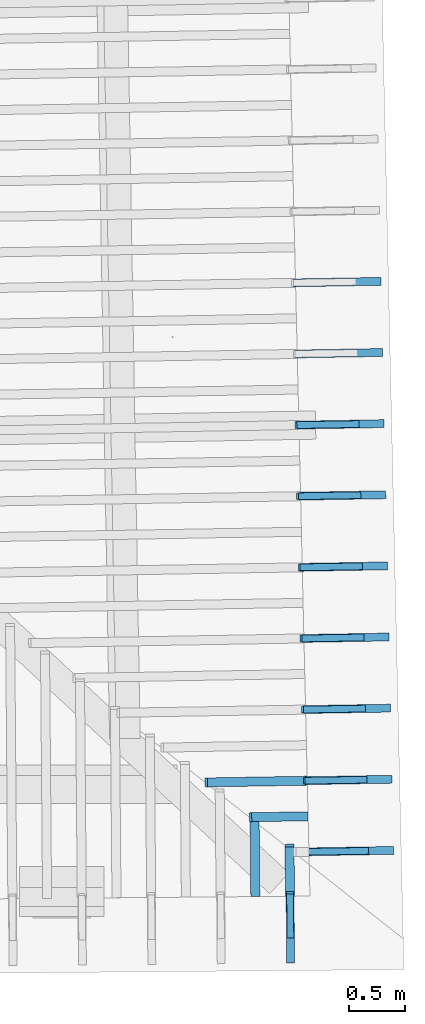
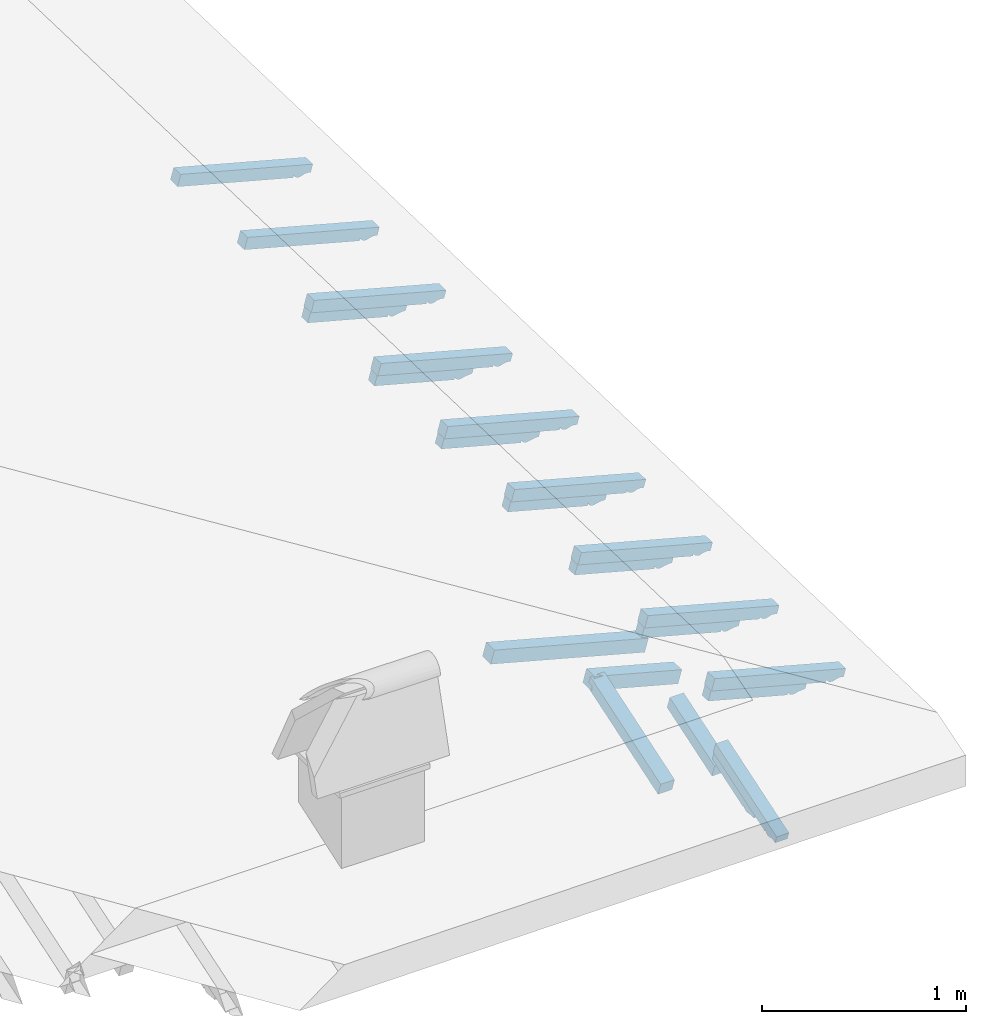
# One storey, part 11 of 19: 22 beams, 6 elements without a shape of their own.
"""IFC4 building model written with IfcOpenShell, lengths in metres."""

import ifcopenshell
import ifcopenshell.guid

model = None  # the IFC model being written
_history = None  # IfcOwnerHistory: only IFC2X3 demands one
_inside = {}  # id of a spatial element -> (the spatial element, [elements in it])
_under = {}  # id of a project, library or spatial element -> (it, [spatial elements below it])
_declared = {}  # id of a project -> (the project, [libraries it declares])
_typed = {}  # id of a type object -> (the type object, [elements of that type])
_made_of = {}  # id of a material, layer set ... -> (it, [elements and type objects made of it])


def new_model(schema):
    """Start an empty IFC model of exactly this schema.

    Asked for "IFC4X3", IfcOpenShell would pick the latest addendum, in which some entities
    have other attributes; the version numbers below select the first issue.
    IFC2X3 requires an IfcOwnerHistory on every rooted entity: one is made here for all.
    """
    global model, _history
    if schema == "IFC4X3":
        model = ifcopenshell.file(schema_version=(4, 3, 0, 0))
    else:
        model = ifcopenshell.file(schema=schema)
    _inside.clear()
    _under.clear()
    _declared.clear()
    _typed.clear()
    _made_of.clear()
    _history = None
    if model.schema == "IFC2X3":
        org = make("IfcOrganization", Name="unknown")
        user = make(
            "IfcPersonAndOrganization",
            ThePerson=make("IfcPerson", FamilyName="unknown"),
            TheOrganization=org,
        )
        app = make(
            "IfcApplication",
            ApplicationDeveloper=org,
            Version="unknown",
            ApplicationFullName="unknown",
            ApplicationIdentifier="unknown",
        )
        _history = make(
            "IfcOwnerHistory",
            OwningUser=user,
            OwningApplication=app,
            ChangeAction="ADDED",
            CreationDate=0,
        )
    return model


def make(cls, **values):
    """One entity of the class cls with the attributes given. An attribute that is None is left unset."""
    return model.create_entity(
        cls, **{name: value for name, value in values.items() if value is not None}
    )


def entity(cls, *values):
    """Any entity or typed value of the class cls, its attributes in the order of the schema. None: left unset."""
    e = model.create_entity(cls)
    for i, value in enumerate(values):
        if value is not None:
            e[i] = value
    return e


def rooted(cls, **values):
    """An entity with a GlobalId (a new one), such as an element, a storey or a relation."""
    return make(cls, GlobalId=ifcopenshell.guid.new(), OwnerHistory=_history, **values)


def si_unit(unit_type, name, prefix=None):
    """IfcSIUnit, for example si_unit("LENGTHUNIT", "METRE", prefix="MILLI")."""
    return make("IfcSIUnit", UnitType=unit_type, Prefix=prefix, Name=name)


def converted_unit(unit_type, name, factor, base, dimensions=None, offset=None):
    """IfcConversionBasedUnit, such as the inch: factor (a typed value) times the base unit."""
    return make(
        "IfcConversionBasedUnit"
        if offset is None
        else "IfcConversionBasedUnitWithOffset",
        ConversionOffset=offset,
        Dimensions=None
        if dimensions is None
        else entity("IfcDimensionalExponents", *dimensions),
        UnitType=unit_type,
        Name=name,
        ConversionFactor=make(
            "IfcMeasureWithUnit", ValueComponent=factor, UnitComponent=base
        ),
    )


def derived_unit(unit_type, elements):
    """IfcDerivedUnit: a product of units, each with its exponent."""
    return make(
        "IfcDerivedUnit",
        Elements=[
            make("IfcDerivedUnitElement", Unit=unit, Exponent=power)
            for unit, power in elements
        ],
        UnitType=unit_type,
    )


def assignment(units):
    """IfcUnitAssignment: the units of a project."""
    return None if units is None else make("IfcUnitAssignment", Units=units)


def point(xyz):
    """IfcCartesianPoint."""
    return None if xyz is None else make("IfcCartesianPoint", Coordinates=xyz)


def direction(xyz):
    """IfcDirection."""
    return None if xyz is None else make("IfcDirection", DirectionRatios=xyz)


def frame(location, z_axis=None, x_axis=None):
    """IfcAxis2Placement3D, a coordinate frame: its origin and axes. An axis left out is left unset."""
    return make(
        "IfcAxis2Placement3D",
        Location=point(location),
        Axis=direction(z_axis),
        RefDirection=direction(x_axis),
    )


def origin():
    """The frame at (0, 0, 0) with its axes left unset."""
    return frame((0.0, 0.0, 0.0))


def place(relative_to, where):
    """IfcLocalPlacement: puts the frame where relative to a parent placement (None: the world)."""
    return make(
        "IfcLocalPlacement", PlacementRelTo=relative_to, RelativePlacement=where
    )


def context(
    kind, dimensions, precision=None, world=None, true_north=None, identifier=None
):
    """IfcGeometricRepresentationContext, for example the 3D "Model" context."""
    return make(
        "IfcGeometricRepresentationContext",
        ContextIdentifier=identifier,
        ContextType=kind,
        CoordinateSpaceDimension=dimensions,
        Precision=precision,
        WorldCoordinateSystem=world,
        TrueNorth=true_north,
    )


def subcontext(parent, identifier, kind, view, scale=None):
    """IfcGeometricRepresentationSubContext, for example "Body" below "Model"."""
    return make(
        "IfcGeometricRepresentationSubContext",
        ContextIdentifier=identifier,
        ContextType=kind,
        ParentContext=parent,
        TargetScale=scale,
        TargetView=view,
    )


def project(units=None, contexts=None):
    """IfcProject with its units and contexts."""
    return rooted(
        "IfcProject",
        Name="project",
        RepresentationContexts=contexts,
        UnitsInContext=assignment(units),
    )


def spatial(cls, under=None, at=None, **own):
    """A site, building, storey or space (cls), placed at a placement, below another one or the project."""
    s = rooted(cls, ObjectPlacement=at, **own)
    if under is not None:
        _under.setdefault(under.id(), (under, []))[1].append(s)
    return s


def point_list(points):
    """IfcCartesianPointList2D or 3D."""
    cls = (
        "IfcCartesianPointList2D" if len(points[0]) == 2 else "IfcCartesianPointList3D"
    )
    return make(cls, CoordList=points)


def line(*indices):
    """IfcLineIndex: a straight run through numbered points of an indexed curve."""
    return model.create_entity("IfcLineIndex", indices)


def arc(*indices):
    """IfcArcIndex: an arc through three numbered points of an indexed curve."""
    return model.create_entity("IfcArcIndex", indices)


def indexed_curve(points, segments=None, self_intersect=None):
    """IfcIndexedPolyCurve: lines and arcs through numbered points (the first is 1)."""
    return make(
        "IfcIndexedPolyCurve",
        Points=point_list(points),
        Segments=segments,
        SelfIntersect=self_intersect,
    )


def outline(outer, holes=None, kind="AREA"):
    """IfcArbitraryClosedProfileDef: a profile drawn as a closed curve; with holes, ...WithVoids."""
    if holes is None:
        return make("IfcArbitraryClosedProfileDef", ProfileType=kind, OuterCurve=outer)
    return make(
        "IfcArbitraryProfileDefWithVoids",
        ProfileType=kind,
        OuterCurve=outer,
        InnerCurves=holes,
    )


def extrude(swept, where, along, depth):
    """IfcExtrudedAreaSolid: the profile swept, set in the frame where, extruded along a direction by depth."""
    return make(
        "IfcExtrudedAreaSolid",
        SweptArea=swept,
        Position=where,
        ExtrudedDirection=direction(along),
        Depth=depth,
    )


def shape(context_of_items, identifier, shape_type, items):
    """IfcShapeRepresentation: the items that make up one representation, for example the "Body"."""
    return make(
        "IfcShapeRepresentation",
        ContextOfItems=context_of_items,
        RepresentationIdentifier=identifier,
        RepresentationType=shape_type,
        Items=items,
    )


def source(mapping_origin, context_of_items, identifier, shape_type, items):
    """IfcRepresentationMap: a shape defined once, which mapped items show again and again."""
    return make(
        "IfcRepresentationMap",
        MappingOrigin=mapping_origin,
        MappedRepresentation=shape(context_of_items, identifier, shape_type, items),
    )


def transform(
    local_origin,
    x_axis=None,
    y_axis=None,
    z_axis=None,
    scale=None,
    scale2=None,
    scale3=None,
    uniform=True,
):
    """IfcCartesianTransformationOperator3D, or its non-uniform kind. x_axis, y_axis, z_axis: its Axis1, 2, 3."""
    if uniform:
        return make(
            "IfcCartesianTransformationOperator3D",
            Axis1=direction(x_axis),
            Axis2=direction(y_axis),
            LocalOrigin=point(local_origin),
            Scale=scale,
            Axis3=direction(z_axis),
        )
    return make(
        "IfcCartesianTransformationOperator3DnonUniform",
        Axis1=direction(x_axis),
        Axis2=direction(y_axis),
        LocalOrigin=point(local_origin),
        Scale=scale,
        Axis3=direction(z_axis),
        Scale2=scale2,
        Scale3=scale3,
    )


def mapped(mapping_source, mapping_target):
    """IfcMappedItem: shows the shape of a source again, moved by a transform."""
    return make(
        "IfcMappedItem", MappingSource=mapping_source, MappingTarget=mapping_target
    )


def material(Name=None, Category=None):
    """IfcMaterial."""
    return make("IfcMaterial", Name=Name, Category=Category)


def made_of(thing, what):
    """Note that an element or type object is made of a material, layer set ...; save() writes the relation."""
    if what is not None:
        _made_of.setdefault(what.id(), (what, []))[1].append(thing)
    return thing


def type_object(cls, material=None, **own):
    """A type object (cls), such as IfcWallType, which elements share."""
    return made_of(rooted(cls, **own), material)


def type_shapes(of_type, sources):
    """Give a type object the sources (RepresentationMaps) that its elements show as mapped items."""
    of_type.RepresentationMaps = sources


def element(
    cls,
    number,
    at=None,
    inside=None,
    cuts=None,
    type_object=None,
    material=None,
    context=None,
    identifier="Body",
    shape_type=None,
    held_by="IfcProductDefinitionShape",
    body=None,
    shapes=None,
    **own,
):
    """One element of the class cls, such as IfcWall. Its Tag is "e" and its number.

    at: its placement. inside: the storey or other place that contains it. cuts: it is an
    opening in that element (IfcRelVoidsElement). A single representation is given by context,
    identifier, shape_type and body (its items); several are given by shapes. held_by: the class
    of the entity that holds the representations. save() writes the other relations.
    """
    e = rooted(cls, Tag="e%d" % number, ObjectPlacement=at, **own)
    if body is not None:
        shapes = [shape(context, identifier, shape_type, body)]
    if shapes is not None:
        e.Representation = make(held_by, Representations=shapes)
    if inside is not None:
        _inside.setdefault(inside.id(), (inside, []))[1].append(e)
    if cuts is not None:
        rooted(
            "IfcRelVoidsElement", RelatingBuildingElement=cuts, RelatedOpeningElement=e
        )
    if type_object is not None:
        _typed.setdefault(type_object.id(), (type_object, []))[1].append(e)
    return made_of(e, material)


def aggregate(whole, parts):
    """IfcRelAggregates: a whole, such as a stair, and the parts it consists of."""
    return rooted("IfcRelAggregates", RelatingObject=whole, RelatedObjects=parts)


def save(model, path):
    """Write the relations noted so far, then the file.

    IfcRelAggregates (storeys below a building ...), IfcRelContainedInSpatialStructure (elements
    in a storey), IfcRelDefinesByType, IfcRelAssociatesMaterial and IfcRelDeclares: one each for
    every whole, place, type object, material and project.
    """
    for whole, parts in _under.values():
        aggregate(whole, parts)
    for where, things in _inside.values():
        rooted(
            "IfcRelContainedInSpatialStructure",
            RelatedElements=things,
            RelatingStructure=where,
        )
    for kind, things in _typed.values():
        rooted("IfcRelDefinesByType", RelatedObjects=things, RelatingType=kind)
    for what, things in _made_of.values():
        rooted("IfcRelAssociatesMaterial", RelatedObjects=things, RelatingMaterial=what)
    for by, libraries in _declared.values():
        rooted("IfcRelDeclares", RelatingContext=by, RelatedDefinitions=libraries)
    model.write(path)


model = new_model("IFC4")

# Units and contexts
model_context = context("Model", 3, precision=1e-05, world=origin(), true_north=direction((6.123233995736766e-17, 1.0)))
body_context = subcontext(model_context, "Body", "Model", "MODEL_VIEW")
ifc_project = project(units=[si_unit("LENGTHUNIT", "METRE"), si_unit("AREAUNIT", "SQUARE_METRE"), si_unit("VOLUMEUNIT", "CUBIC_METRE"), converted_unit("PLANEANGLEUNIT", "DEGREE", entity("IfcPlaneAngleMeasure", 0.017453292519943278), si_unit("PLANEANGLEUNIT", "RADIAN"), dimensions=[0, 0, 0, 0, 0, 0, 0]), derived_unit("THERMALTRANSMITTANCEUNIT", [(si_unit("MASSUNIT", "GRAM", prefix="KILO"), 1), (si_unit("THERMODYNAMICTEMPERATUREUNIT", "KELVIN"), -1), (si_unit("TIMEUNIT", "SECOND"), -3)])], contexts=[model_context])

# Site, building, storey
site_placement = place(None, origin())
site = spatial("IfcSite", under=ifc_project, at=site_placement, CompositionType="ELEMENT")
building_placement = place(site_placement, origin())
building = spatial("IfcBuilding", under=site, at=building_placement, CompositionType="ELEMENT")
storey_placement = place(building_placement, frame((0.0, 0.0, 3.28)))
storey = spatial("IfcBuildingStorey", under=building, at=storey_placement, Name="Livello Copertura", CompositionType="ELEMENT", Elevation=3.28)

# Assembly, beams
assembly_1_placement = place(storey_placement, origin())
assembly_1 = element("IfcElementAssembly", 1, at=assembly_1_placement, inside=storey, Name="Sistema di travi strutturali:Sistema di travi strutturali", ObjectType="Sistema di travi strutturali:Sistema di travi strutturali", AssemblyPlace="NOTDEFINED", PredefinedType="BEAM_GRID")
ifc_material = material(Name="Legno - Legno da costruzione", Category="Legno")
beam_type_1 = type_object("IfcBeamType", Name="Legno:80x80", PredefinedType="JOIST", material=ifc_material)
shared_shape_1 = source(origin(), body_context, "Body", "SweptSolid", [
    extrude(outline(indexed_curve([(-0.259, -0.04000000000000169), (0.259, -0.04000000000000169), (0.259, 0.04000000000000169), (-0.259, 0.04000000000000169), (-0.259, -0.04000000000000169)], self_intersect=False)), frame((0.0, 0.0, -0.040000000000005476), z_axis=(0.0, 0.0, 1.0), x_axis=(-1.0, 0.0, 0.0)), (0.0, 0.0, 1.0), 0.07999999999999997),
])
type_shapes(beam_type_1, [shared_shape_1])
beam_1_placement = place(assembly_1_placement, frame((4.167819767114368, -2.4415856783756533, 0.1458502023403423), z_axis=(0.2688805697492538, 0.0045944674406682845, 0.9631625667976582), x_axis=(-0.9630219859926786, -0.016455533263027823, 0.2689198206152657)))
beam_1 = element("IfcBeam", 2, at=beam_1_placement, type_object=beam_type_1, material=ifc_material, Name="Legno:80x80", ObjectType="Legno:80x80", PredefinedType="JOIST", context=body_context, shape_type="MappedRepresentation", body=[
    mapped(shared_shape_1, transform((0.0, 0.0, 0.0), scale=1.0)),
])
beam_type_2 = type_object("IfcBeamType", Name="Legno:80x80", PredefinedType="JOIST", material=ifc_material)
shared_shape_2 = source(origin(), body_context, "Body", "SweptSolid", [
    extrude(outline(indexed_curve([(-0.458, -0.04000000000000169), (0.458, -0.04000000000000169), (0.458, 0.04000000000000169), (-0.458, 0.04000000000000169), (-0.458, -0.04000000000000169)], self_intersect=False)), frame((0.0, 0.0, -0.040000000000005476), z_axis=(0.0, 0.0, 1.0), x_axis=(-1.0, 0.0, 0.0)), (0.0, 0.0, 1.0), 0.07999999999999997),
])
type_shapes(beam_type_2, [shared_shape_2])
beam_2_placement = place(assembly_1_placement, frame((3.968806242014773, -2.1299403169773568, 0.19992105947898664), z_axis=(0.2688805697492532, 0.004594467440668273, 0.9631625667976584), x_axis=(-0.9630219859926787, -0.016455533263027917, 0.2689198206152651)))
beam_2 = element("IfcBeam", 3, at=beam_2_placement, type_object=beam_type_2, material=ifc_material, Name="Legno:80x80", ObjectType="Legno:80x80", PredefinedType="JOIST", context=body_context, shape_type="MappedRepresentation", body=[
    mapped(shared_shape_2, transform((0.0, 0.0, 0.0), scale=1.0)),
])
aggregate(assembly_1, [beam_1, beam_2])

assembly_2_placement = place(storey_placement, origin())
assembly_2 = element("IfcElementAssembly", 4, at=assembly_2_placement, inside=storey, Name="Sistema di travi strutturali:Sistema di travi strutturali", ObjectType="Sistema di travi strutturali:Sistema di travi strutturali", AssemblyPlace="NOTDEFINED", PredefinedType="BEAM_GRID")
beam_type_3 = type_object("IfcBeamType", Name="Legno:80x80", PredefinedType="JOIST", material=ifc_material)
shared_shape_3 = source(origin(), body_context, "Body", "SweptSolid", [
    extrude(outline(indexed_curve([(-0.23, -0.04000000000000169), (0.23, -0.04000000000000169), (0.23, 0.04000000000000169), (-0.23, 0.04000000000000169), (-0.23, -0.04000000000000169)], self_intersect=False)), frame((0.0, 0.0, -0.040000000000005476), z_axis=(0.0, 0.0, 1.0), x_axis=(-1.0, 0.0, 0.0)), (0.0, 0.0, 1.0), 0.07999999999999997),
])
type_shapes(beam_type_3, [shared_shape_3])
beam_3_placement = place(assembly_2_placement, frame((4.266041665858084, -2.9151498456056375, 0.049164794716471616), z_axis=(0.00339332276243598, -0.32555047006150756, 0.9455185755993171), x_axis=(-0.007932350194779074, 0.9454855083215808, 0.3255675527049179)))
beam_3 = element("IfcBeam", 5, at=beam_3_placement, type_object=beam_type_3, material=ifc_material, Name="Legno:80x80", ObjectType="Legno:80x80", PredefinedType="JOIST", context=body_context, shape_type="MappedRepresentation", body=[
    mapped(shared_shape_3, transform((0.0, 0.0, 0.0), scale=1.0)),
])
beam_type_4 = type_object("IfcBeamType", Name="Legno:80x80", PredefinedType="JOIST", material=ifc_material)
shared_shape_4 = source(origin(), body_context, "Body", "SweptSolid", [
    extrude(outline(indexed_curve([(-0.3605, -0.04000000000000169), (0.3605, -0.04000000000000169), (0.3605, 0.04000000000000169), (-0.3605, 0.04000000000000169), (-0.3605, -0.04000000000000169)], self_intersect=False)), frame((0.0, 0.0, -0.040000000000005476), z_axis=(0.0, 0.0, 1.0), x_axis=(-1.0, 0.0, 0.0)), (0.0, 0.0, 1.0), 0.07999999999999997),
])
type_shapes(beam_type_4, [shared_shape_4])
beam_4_placement = place(assembly_2_placement, frame((3.9577175453328666, -2.7943622457907162, 0.09185957004454759), z_axis=(0.00339332276243599, -0.3255504700615087, 0.9455185755993166), x_axis=(-0.007932350194779364, 0.9454855083215803, 0.32556755270491905)))
beam_4 = element("IfcBeam", 6, at=beam_4_placement, type_object=beam_type_4, material=ifc_material, Name="Legno:80x80", ObjectType="Legno:80x80", PredefinedType="JOIST", context=body_context, shape_type="MappedRepresentation", body=[
    mapped(shared_shape_4, transform((0.0, 0.0, 0.0), scale=1.0)),
])
aggregate(assembly_2, [beam_3, beam_4])

assembly_3_placement = place(storey_placement, origin())
assembly_3 = element("IfcElementAssembly", 7, at=assembly_3_placement, inside=storey, Name="Sistema di travi strutturali:Sistema di travi strutturali", ObjectType="Sistema di travi strutturali:Sistema di travi strutturali", AssemblyPlace="NOTDEFINED", PredefinedType="BEAM_GRID")
beam_type_5 = type_object("IfcBeamType", Name="70x70:70x70", PredefinedType="JOIST", material=ifc_material)
shared_shape_5 = source(origin(), body_context, "Body", "SweptSolid", [
    extrude(outline(indexed_curve([(-0.04357142857143151, -0.5254285714285709), (0.026428571428568488, -0.5254285714285709), (0.026428571428568488, 0.16057142857142903), (0.01242857142858439, 0.16057142857142565), (0.026181867029378907, 0.18428103309933028), (0.01842857142857074, 0.21057142857142916), (0.0060141181108477005, 0.23356700408641207), (0.0034285714285709062, 0.259571428571429), (-0.04357142857143151, 0.259571428571429)], segments=[line(1, 2, 3, 4), arc(4, 5, 6), arc(6, 7, 8), line(8, 9, 1)], self_intersect=False)), frame((-0.09792857142857095, -0.03500000000000078, -0.008571428571433235), z_axis=(0.0, 1.0, 0.0), x_axis=(0.0, 0.0, -1.0)), (0.0, 0.0, 1.0), 0.06999999999999999),
])
type_shapes(beam_type_5, [shared_shape_5])
beam_5_placement = place(assembly_3_placement, frame((4.719811399850674, 2.2935361683928694, 0.1064103460268555), z_axis=(0.26888056974925345, 0.004594467440668775, 0.9631625667976582), x_axis=(-0.9630219859926785, -0.016455533263032052, 0.2689198206152654)))
beam_5 = element("IfcBeam", 8, at=beam_5_placement, type_object=beam_type_5, material=ifc_material, Name="70x70:70x70", ObjectType="70x70:70x70", PredefinedType="JOIST", context=body_context, shape_type="MappedRepresentation", body=[
    mapped(shared_shape_5, transform((0.0, 0.0, 0.0), scale=1.0)),
])
beam_type_6 = type_object("IfcBeamType", Name="70x70:70x70", PredefinedType="JOIST", material=ifc_material)
shared_shape_6 = source(origin(), body_context, "Body", "SweptSolid", [
    extrude(outline(indexed_curve([(-0.04357142857143147, -0.524714285714285), (0.02642857142856849, -0.524714285714285), (0.02642857142856849, 0.16028571428571473), (0.01242857142858438, 0.16028571428571134), (0.0261818670293789, 0.183995318813616), (0.018428571428570698, 0.21028571428571488), (0.0060141181108476615, 0.2332812898006978), (0.003428571428570863, 0.2592857142857147), (-0.04357142857143147, 0.2592857142857147)], segments=[line(1, 2, 3, 4), arc(4, 5, 6), arc(6, 7, 8), line(8, 9, 1)], self_intersect=False)), frame((-0.0977142857142851, -0.03500000000000078, -0.008571428571433224), z_axis=(0.0, 1.0, 0.0), x_axis=(0.0, 0.0, -1.0)), (0.0, 0.0, 1.0), 0.06999999999999999),
])
type_shapes(beam_type_6, [shared_shape_6])
beam_6_placement = place(assembly_3_placement, frame((4.7342594064271, 1.663691080479858, 0.10538145897799156), z_axis=(0.26888056974925306, 0.004594467440668766, 0.9631625667976583), x_axis=(-0.9630219859926786, -0.01645553326303219, 0.268919820615265)))
beam_6 = element("IfcBeam", 9, at=beam_6_placement, type_object=beam_type_6, material=ifc_material, Name="70x70:70x70", ObjectType="70x70:70x70", PredefinedType="JOIST", context=body_context, shape_type="MappedRepresentation", body=[
    mapped(shared_shape_6, transform((0.0, 0.0, 0.0), scale=1.0)),
])
beam_7_placement = place(assembly_3_placement, frame((4.7487074130035225, 1.033845992566848, 0.1043525719291285), z_axis=(0.2688805697492534, 0.004594467440668773, 0.9631625667976583), x_axis=(-0.9630219859926785, -0.01645553326303234, 0.2689198206152653)))
beam_7 = element("IfcBeam", 10, at=beam_7_placement, type_object=beam_type_6, material=ifc_material, Name="70x70:70x70", ObjectType="70x70:70x70", PredefinedType="JOIST", context=body_context, shape_type="MappedRepresentation", body=[
    mapped(shared_shape_6, transform((0.0, 0.0, 0.0), scale=1.0)),
])
beam_type_7 = type_object("IfcBeamType", Name="70x70:70x70", PredefinedType="JOIST", material=ifc_material)
shared_shape_7 = source(origin(), body_context, "Body", "SweptSolid", [
    extrude(outline(indexed_curve([(-0.04357142857143148, -0.5239999999999997), (0.026428571428568505, -0.5239999999999997), (0.026428571428568505, 0.1600000000000005), (0.012428571428584407, 0.15999999999999712), (0.026181867029378924, 0.18370960452790178), (0.018428571428570687, 0.21000000000000066), (0.006014118110847652, 0.23299557551498357), (0.0034285714285708577, 0.25900000000000045), (-0.04357142857143148, 0.25900000000000045)], segments=[line(1, 2, 3, 4), arc(4, 5, 6), arc(6, 7, 8), line(8, 9, 1)], self_intersect=False)), frame((-0.09749999999999955, -0.03500000000000078, -0.008571428571433216), z_axis=(0.0, 1.0, 0.0), x_axis=(0.0, 0.0, -1.0)), (0.0, 0.0, 1.0), 0.06999999999999999),
])
type_shapes(beam_type_7, [shared_shape_7])
beam_8_placement = place(assembly_3_placement, frame((4.763155419579946, 0.40400090465383615, 0.10332368488026522), z_axis=(0.26888056974925373, 0.004594467440668777, 0.9631625667976582), x_axis=(-0.9630219859926785, -0.01645553326303225, 0.26891982061526565)))
beam_8 = element("IfcBeam", 11, at=beam_8_placement, type_object=beam_type_7, material=ifc_material, Name="70x70:70x70", ObjectType="70x70:70x70", PredefinedType="JOIST", context=body_context, shape_type="MappedRepresentation", body=[
    mapped(shared_shape_7, transform((0.0, 0.0, 0.0), scale=1.0)),
])
beam_type_8 = type_object("IfcBeamType", Name="70x70:70x70", PredefinedType="JOIST", material=ifc_material)
shared_shape_8 = source(origin(), body_context, "Body", "SweptSolid", [
    extrude(outline(indexed_curve([(-0.043571428571431495, -0.5232857142857139), (0.026428571428568495, -0.5232857142857139), (0.026428571428568495, 0.15971428571428622), (0.012428571428584398, 0.15971428571428284), (0.026181867029378917, 0.18342389024218747), (0.01842857142857071, 0.20971428571428635), (0.006014118110847676, 0.2327098612292693), (0.003428571428570882, 0.2587142857142862), (-0.043571428571431495, 0.2587142857142862)], segments=[line(1, 2, 3, 4), arc(4, 5, 6), arc(6, 7, 8), line(8, 9, 1)], self_intersect=False)), frame((-0.09728571428571382, -0.03500000000000078, -0.008571428571433226), z_axis=(0.0, 1.0, 0.0), x_axis=(0.0, 0.0, -1.0)), (0.0, 0.0, 1.0), 0.06999999999999999),
])
type_shapes(beam_type_8, [shared_shape_8])
beam_9_placement = place(assembly_3_placement, frame((4.77760342615637, -0.22584418325917582, 0.10229479783140172), z_axis=(0.26888056974925334, 0.004594467440668772, 0.9631625667976583), x_axis=(-0.9630219859926786, -0.016455533263032274, 0.2689198206152653)))
beam_9 = element("IfcBeam", 12, at=beam_9_placement, type_object=beam_type_8, material=ifc_material, Name="70x70:70x70", ObjectType="70x70:70x70", PredefinedType="JOIST", context=body_context, shape_type="MappedRepresentation", body=[
    mapped(shared_shape_8, transform((0.0, 0.0, 0.0), scale=1.0)),
])
beam_type_9 = type_object("IfcBeamType", Name="70x70:70x70", PredefinedType="JOIST", material=ifc_material)
shared_shape_9 = source(origin(), body_context, "Body", "SweptSolid", [
    extrude(outline(indexed_curve([(-0.0435714285714315, -0.5225714285714281), (0.02642857142856849, -0.5225714285714281), (0.02642857142856849, 0.15942857142857195), (0.012428571428584397, 0.15942857142856856), (0.026181867029378917, 0.1831381759564732), (0.018428571428570725, 0.20942857142857207), (0.006014118110847691, 0.23242414694355498), (0.0034285714285708967, 0.2584285714285719), (-0.0435714285714315, 0.2584285714285719)], segments=[line(1, 2, 3, 4), arc(4, 5, 6), arc(6, 7, 8), line(8, 9, 1)], self_intersect=False)), frame((-0.0970714285714281, -0.03500000000000078, -0.008571428571433228), z_axis=(0.0, 1.0, 0.0), x_axis=(0.0, 0.0, -1.0)), (0.0, 0.0, 1.0), 0.06999999999999999),
])
type_shapes(beam_type_9, [shared_shape_9])
beam_10_placement = place(assembly_3_placement, frame((4.792051432732794, -0.8556892711721877, 0.10126591078253866), z_axis=(0.2688805697492535, 0.0045944674406687746, 0.9631625667976582), x_axis=(-0.9630219859926785, -0.0164555332630323, 0.2689198206152654)))
beam_10 = element("IfcBeam", 13, at=beam_10_placement, type_object=beam_type_9, material=ifc_material, Name="70x70:70x70", ObjectType="70x70:70x70", PredefinedType="JOIST", context=body_context, shape_type="MappedRepresentation", body=[
    mapped(shared_shape_9, transform((0.0, 0.0, 0.0), scale=1.0)),
])
beam_11_placement = place(assembly_3_placement, frame((4.806499439309217, -1.485534359085202, 0.10023702373367382), z_axis=(0.26888056974925323, 0.004594467440668769, 0.9631625667976583), x_axis=(-0.9630219859926786, -0.016455533263032292, 0.2689198206152652)))
beam_11 = element("IfcBeam", 14, at=beam_11_placement, type_object=beam_type_9, material=ifc_material, Name="70x70:70x70", ObjectType="70x70:70x70", PredefinedType="JOIST", context=body_context, shape_type="MappedRepresentation", body=[
    mapped(shared_shape_9, transform((0.0, 0.0, 0.0), scale=1.0)),
])
beam_type_10 = type_object("IfcBeamType", Name="70x70:70x70", PredefinedType="JOIST", material=ifc_material)
shared_shape_10 = source(origin(), body_context, "Body", "SweptSolid", [
    extrude(outline(indexed_curve([(-0.04357142857143155, -0.5218571428571424), (0.026428571428568436, -0.5218571428571424), (0.026428571428568436, 0.15914285714285764), (0.01242857142858434, 0.15914285714285425), (0.026181867029378855, 0.1828524616707589), (0.018428571428570857, 0.2091428571428578), (0.006014118110847821, 0.2321384326578407), (0.003428571428571027, 0.2581428571428576), (-0.04357142857143155, 0.2581428571428576)], segments=[line(1, 2, 3, 4), arc(4, 5, 6), arc(6, 7, 8), line(8, 9, 1)], self_intersect=False)), frame((-0.09685714285714238, -0.03500000000000078, -0.008571428571433283), z_axis=(0.0, 1.0, 0.0), x_axis=(0.0, 0.0, -1.0)), (0.0, 0.0, 1.0), 0.06999999999999999),
])
type_shapes(beam_type_10, [shared_shape_10])
beam_12_placement = place(assembly_3_placement, frame((4.820947445885641, -2.115379446998214, 0.09920813668481099), z_axis=(0.26888056974925356, 0.004594467440668777, 0.9631625667976582), x_axis=(-0.9630219859926785, -0.016455533263032448, 0.26891982061526554)))
beam_12 = element("IfcBeam", 15, at=beam_12_placement, type_object=beam_type_10, material=ifc_material, Name="70x70:70x70", ObjectType="70x70:70x70", PredefinedType="JOIST", context=body_context, shape_type="MappedRepresentation", body=[
    mapped(shared_shape_10, transform((0.0, 0.0, 0.0), scale=1.0)),
])

assembly_4_placement = place(storey_placement, origin())
assembly_4 = element("IfcElementAssembly", 16, at=assembly_4_placement, inside=storey, Name="Sistema di travi strutturali:Sistema di travi strutturali", ObjectType="Sistema di travi strutturali:Sistema di travi strutturali", AssemblyPlace="NOTDEFINED", PredefinedType="BEAM_GRID")
beam_type_11 = type_object("IfcBeamType", Name="60x60:60x60", PredefinedType="JOIST", material=ifc_material)
shared_shape_11 = source(origin(), body_context, "Body", "SweptSolid", [
    extrude(outline(indexed_curve([(-0.03585714285711785, -0.37342857142857155), (0.024142857142882126, -0.37342857142857155), (0.024142857142882126, 0.1015714285714284), (0.007142857142882192, 0.1015714285714284), (0.022800314198399122, 0.1191678446269961), (0.02014285714279423, 0.14257142857142951), (0.0060973625587454365, 0.17072501701940931), (-0.00385714285720498, 0.20057142857142835), (-0.03585714285711785, 0.20057142857142843)], segments=[line(1, 2, 3, 4), arc(4, 5, 6), arc(6, 7, 8), line(8, 9, 1)], self_intersect=False)), frame((0.053571428571428464, -0.030000000000000786, -0.005857142857119588), z_axis=(0.0, 1.0, 0.0), x_axis=(0.0, 0.0, -1.0)), (0.0, 0.0, 1.0), 0.059999999999999984),
])
type_shapes(beam_type_11, [shared_shape_11])
beam_13_placement = place(assembly_4_placement, frame((4.73123017596982, 1.0335473521832044, 0.0417470050872808), z_axis=(0.2688805697492534, 0.004594467440668774, 0.9631625667976583), x_axis=(-0.9630219859926785, -0.01645553326303234, 0.2689198206152653)))
beam_13 = element("IfcBeam", 17, at=beam_13_placement, type_object=beam_type_11, material=ifc_material, Name="60x60:60x60", ObjectType="60x60:60x60", PredefinedType="JOIST", context=body_context, shape_type="MappedRepresentation", body=[
    mapped(shared_shape_11, transform((0.0, 0.0, 0.0), scale=1.0)),
])
beam_type_12 = type_object("IfcBeamType", Name="60x60:60x60", PredefinedType="JOIST", material=ifc_material)
shared_shape_12 = source(origin(), body_context, "Body", "SweptSolid", [
    extrude(outline(indexed_curve([(-0.03585714285711763, -0.372714285714286), (0.024142857142882352, -0.372714285714286), (0.024142857142882352, 0.10128571428571417), (0.007142857142882415, 0.10128571428571417), (0.022800314198399348, 0.11888213034128188), (0.02014285714279368, 0.14228571428571532), (0.006097362558744881, 0.1704393027336951), (-0.0038571428572055353, 0.20028571428571412), (-0.03585714285711763, 0.2002857142857142)], segments=[line(1, 2, 3, 4), arc(4, 5, 6), arc(6, 7, 8), line(8, 9, 1)], self_intersect=False)), frame((0.05378571428571413, -0.030000000000000786, -0.005857142857119365), z_axis=(0.0, 1.0, 0.0), x_axis=(0.0, 0.0, -1.0)), (0.0, 0.0, 1.0), 0.059999999999999984),
])
type_shapes(beam_type_12, [shared_shape_12])
beam_14_placement = place(assembly_4_placement, frame((4.745678182546245, 0.40370226427019273, 0.04071811803841685), z_axis=(0.26888056974925356, 0.004594467440668776, 0.9631625667976582), x_axis=(-0.9630219859926785, -0.016455533263032247, 0.2689198206152655)))
beam_14 = element("IfcBeam", 18, at=beam_14_placement, type_object=beam_type_12, material=ifc_material, Name="60x60:60x60", ObjectType="60x60:60x60", PredefinedType="JOIST", context=body_context, shape_type="MappedRepresentation", body=[
    mapped(shared_shape_12, transform((0.0, 0.0, 0.0), scale=1.0)),
])
beam_type_13 = type_object("IfcBeamType", Name="60x60:60x60", PredefinedType="JOIST", material=ifc_material)
shared_shape_13 = source(origin(), body_context, "Body", "SweptSolid", [
    extrude(outline(indexed_curve([(-0.03585714285711792, -0.3720000000000002), (0.02414285714288206, -0.3720000000000002), (0.02414285714288206, 0.10099999999999987), (0.007142857142882124, 0.10099999999999987), (0.022800314198399056, 0.1185964160555676), (0.0201428571427944, 0.14200000000000101), (0.006097362558745606, 0.17015358844798079), (-0.003857142857204811, 0.19999999999999982), (-0.03585714285711792, 0.19999999999999987)], segments=[line(1, 2, 3, 4), arc(4, 5, 6), arc(6, 7, 8), line(8, 9, 1)], self_intersect=False)), frame((0.053999999999999854, -0.030000000000000786, -0.005857142857119656), z_axis=(0.0, 1.0, 0.0), x_axis=(0.0, 0.0, -1.0)), (0.0, 0.0, 1.0), 0.059999999999999984),
])
type_shapes(beam_type_13, [shared_shape_13])
beam_15_placement = place(assembly_4_placement, frame((4.760126189122668, -0.22614282364281937, 0.039689230989554014), z_axis=(0.2688805697492539, 0.0045944674406687815, 0.9631625667976581), x_axis=(-0.9630219859926784, -0.016455533263032278, 0.2689198206152658)))
beam_15 = element("IfcBeam", 19, at=beam_15_placement, type_object=beam_type_13, material=ifc_material, Name="60x60:60x60", ObjectType="60x60:60x60", PredefinedType="JOIST", context=body_context, shape_type="MappedRepresentation", body=[
    mapped(shared_shape_13, transform((0.0, 0.0, 0.0), scale=1.0)),
])
beam_type_14 = type_object("IfcBeamType", Name="60x60:60x60", PredefinedType="JOIST", material=ifc_material)
shared_shape_14 = source(origin(), body_context, "Body", "SweptSolid", [
    extrude(outline(indexed_curve([(-0.03585714285711799, -0.3712857142857145), (0.02414285714288199, -0.3712857142857145), (0.02414285714288199, 0.10071428571428556), (0.007142857142882057, 0.10071428571428556), (0.022800314198398987, 0.11831070176985331), (0.02014285714279457, 0.1417142857142867), (0.006097362558745775, 0.16986787416226648), (-0.003857142857204642, 0.1997142857142855), (-0.03585714285711799, 0.1997142857142856)], segments=[line(1, 2, 3, 4), arc(4, 5, 6), arc(6, 7, 8), line(8, 9, 1)], self_intersect=False)), frame((0.05421428571428558, -0.030000000000000786, -0.005857142857119723), z_axis=(0.0, 1.0, 0.0), x_axis=(0.0, 0.0, -1.0)), (0.0, 0.0, 1.0), 0.059999999999999984),
])
type_shapes(beam_type_14, [shared_shape_14])
beam_16_placement = place(assembly_4_placement, frame((4.774574195699092, -0.8559879115558313, 0.03866034394069118), z_axis=(0.26888056974925306, 0.004594467440668765, 0.9631625667976583), x_axis=(-0.9630219859926786, -0.01645553326303215, 0.268919820615265)))
beam_16 = element("IfcBeam", 20, at=beam_16_placement, type_object=beam_type_14, material=ifc_material, Name="60x60:60x60", ObjectType="60x60:60x60", PredefinedType="JOIST", context=body_context, shape_type="MappedRepresentation", body=[
    mapped(shared_shape_14, transform((0.0, 0.0, 0.0), scale=1.0)),
])
beam_17_placement = place(assembly_4_placement, frame((4.7890222022755164, -1.4858329994688455, 0.03763145689182679), z_axis=(0.2688805697492537, 0.004594467440668778, 0.9631625667976582), x_axis=(-0.9630219859926785, -0.016455533263032274, 0.26891982061526565)))
beam_17 = element("IfcBeam", 21, at=beam_17_placement, type_object=beam_type_14, material=ifc_material, Name="60x60:60x60", ObjectType="60x60:60x60", PredefinedType="JOIST", context=body_context, shape_type="MappedRepresentation", body=[
    mapped(shared_shape_14, transform((0.0, 0.0, 0.0), scale=1.0)),
])
beam_type_15 = type_object("IfcBeamType", Name="60x60:60x60", PredefinedType="JOIST", material=ifc_material)
shared_shape_15 = source(origin(), body_context, "Body", "SweptSolid", [
    extrude(outline(indexed_curve([(-0.03585714285711787, -0.3705714285714287), (0.02414285714288211, -0.3705714285714287), (0.02414285714288211, 0.10042857142857127), (0.007142857142882173, 0.10042857142857127), (0.022800314198399108, 0.118024987484139), (0.020142857142794283, 0.1414285714285724), (0.006097362558745485, 0.1695821598765522), (-0.0038571428572049316, 0.19942857142857123), (-0.03585714285711787, 0.19942857142857132)], segments=[line(1, 2, 3, 4), arc(4, 5, 6), arc(6, 7, 8), line(8, 9, 1)], self_intersect=False)), frame((0.054428571428571305, -0.030000000000000786, -0.005857142857119607), z_axis=(0.0, 1.0, 0.0), x_axis=(0.0, 0.0, -1.0)), (0.0, 0.0, 1.0), 0.059999999999999984),
])
type_shapes(beam_type_15, [shared_shape_15])
beam_18_placement = place(assembly_4_placement, frame((4.803470208851939, -2.1156780873818573, 0.03660256984296395), z_axis=(0.26888056974925334, 0.004594467440668773, 0.9631625667976583), x_axis=(-0.9630219859926786, -0.016455533263032143, 0.2689198206152653)))
beam_18 = element("IfcBeam", 22, at=beam_18_placement, type_object=beam_type_15, material=ifc_material, Name="60x60:60x60", ObjectType="60x60:60x60", PredefinedType="JOIST", context=body_context, shape_type="MappedRepresentation", body=[
    mapped(shared_shape_15, transform((0.0, 0.0, 0.0), scale=1.0)),
])

# Assembly, beam
assembly_5_placement = place(storey_placement, origin())
assembly_5 = element("IfcElementAssembly", 23, at=assembly_5_placement, inside=storey, Name="Sistema di travi strutturali:Sistema di travi strutturali", ObjectType="Sistema di travi strutturali:Sistema di travi strutturali", AssemblyPlace="NOTDEFINED", PredefinedType="BEAM_GRID")
beam_type_16 = type_object("IfcBeamType", Name="70x70:70x70", PredefinedType="JOIST", material=ifc_material)
shared_shape_16 = source(origin(), body_context, "Body", "SweptSolid", [
    extrude(outline(indexed_curve([(-0.043571428571431446, -0.4111428571428566), (0.026428571428568526, -0.4111428571428566), (0.026428571428568526, 0.11485714285714331), (0.012428571428584403, 0.11485714285713992), (0.026181867029378924, 0.13856674738504457), (0.018428571428570642, 0.16485714285714345), (0.006014118110847607, 0.1878527183721263), (0.003428571428570812, 0.21385714285714325), (-0.043571428571431446, 0.21385714285714327)], segments=[line(1, 2, 3, 4), arc(4, 5, 6), arc(6, 7, 8), line(8, 9, 1)], self_intersect=False)), frame((-0.06364285714285657, -0.03500000000000078, -0.008571428571433195), z_axis=(0.0, 1.0, 0.0), x_axis=(0.0, 0.0, -1.0)), (0.0, 0.0, 1.0), 0.06999999999999999),
])
type_shapes(beam_type_16, [shared_shape_16])
beam_19_placement = place(assembly_5_placement, frame((4.271337187555633, -3.463380161015151, 3.059490896784034e-05), z_axis=(0.0033933227624359887, -0.32555047006150867, 0.9455185755993167), x_axis=(-0.007932350194779832, 0.9454855083215804, 0.325567552704919)))
beam_19 = element("IfcBeam", 24, at=beam_19_placement, type_object=beam_type_16, material=ifc_material, Name="70x70:70x70", ObjectType="70x70:70x70", PredefinedType="JOIST", context=body_context, shape_type="MappedRepresentation", body=[
    mapped(shared_shape_16, transform((0.0, 0.0, 0.0), scale=1.0)),
])
aggregate(assembly_5, [beam_19])

assembly_6_placement = place(storey_placement, origin())
assembly_6 = element("IfcElementAssembly", 25, at=assembly_6_placement, inside=storey, Name="Sistema di travi strutturali:Sistema di travi strutturali", ObjectType="Sistema di travi strutturali:Sistema di travi strutturali", AssemblyPlace="NOTDEFINED", PredefinedType="BEAM_GRID")
beam_type_17 = type_object("IfcBeamType", Name="60x60:60x60", PredefinedType="JOIST", material=ifc_material)
shared_shape_17 = source(origin(), body_context, "Body", "SweptSolid", [
    extrude(outline(indexed_curve([(-0.03585714285711792, -0.25985714285714306), (0.02414285714288206, -0.25985714285714306), (0.02414285714288206, 0.056142857142857), (0.007142857142882124, 0.056142857142857), (0.022800314198399056, 0.07373927319842473), (0.0201428571427944, 0.09714285714285814), (0.006097362558745606, 0.1252964455908379), (-0.003857142857204811, 0.15514285714285697), (-0.03585714285711792, 0.15514285714285703)], segments=[line(1, 2, 3, 4), arc(4, 5, 6), arc(6, 7, 8), line(8, 9, 1)], self_intersect=False)), frame((0.08764285714285702, -0.030000000000000786, -0.005857142857119656), z_axis=(0.0, 1.0, 0.0), x_axis=(0.0, 0.0, -1.0)), (0.0, 0.0, 1.0), 0.059999999999999984),
])
type_shapes(beam_type_17, [shared_shape_17])
beam_20_placement = place(assembly_6_placement, frame((4.271116621576074, -3.442219380461153, -0.061428112504987364), z_axis=(0.003393322762435991, -0.3255504700615086, 0.9455185755993168), x_axis=(-0.007932350194779832, 0.9454855083215803, 0.325567552704919)))
beam_20 = element("IfcBeam", 26, at=beam_20_placement, type_object=beam_type_17, material=ifc_material, Name="60x60:60x60", ObjectType="60x60:60x60", PredefinedType="JOIST", context=body_context, shape_type="MappedRepresentation", body=[
    mapped(shared_shape_17, transform((0.0, 0.0, 0.0), scale=1.0)),
])
aggregate(assembly_6, [beam_20])

# Beam
beam_type_18 = type_object("IfcBeamType", Name="60x60:60x60", PredefinedType="JOIST", material=ifc_material)
shared_shape_18 = source(origin(), body_context, "Body", "SweptSolid", [
    extrude(outline(indexed_curve([(-0.03585714285711802, -0.369857142857143), (0.024142857142881967, -0.369857142857143), (0.024142857142881967, 0.10014285714285696), (0.007142857142882028, 0.10014285714285696), (0.022800314198398963, 0.1177392731984247), (0.020142857142794648, 0.1411428571428581), (0.0060973625587458485, 0.16929644559083787), (-0.0038571428572045686, 0.19914285714285695), (-0.03585714285711802, 0.199142857142857)], segments=[line(1, 2, 3, 4), arc(4, 5, 6), arc(6, 7, 8), line(8, 9, 1)], self_intersect=False)), frame((0.05464285714285702, -0.030000000000000786, -0.005857142857119752), z_axis=(0.0, 1.0, 0.0), x_axis=(0.0, 0.0, -1.0)), (0.0, 0.0, 1.0), 0.059999999999999984),
])
type_shapes(beam_type_18, [shared_shape_18])
beam_21_placement = place(assembly_4_placement, frame((4.817918215428362, -2.7455231752948683, 0.03557368279409934), z_axis=(0.2688805697492535, 0.004594467440668774, 0.9631625667976583), x_axis=(-0.9630219859926785, -0.0164555332630326, 0.2689198206152654)))
beam_21 = element("IfcBeam", 27, at=beam_21_placement, type_object=beam_type_18, material=ifc_material, Name="60x60:60x60", ObjectType="60x60:60x60", PredefinedType="JOIST", context=body_context, shape_type="MappedRepresentation", body=[
    mapped(shared_shape_18, transform((0.0, 0.0, 0.0), scale=1.0)),
])

aggregate(assembly_4, [beam_13, beam_14, beam_15, beam_16, beam_17, beam_18, beam_21])

beam_type_19 = type_object("IfcBeamType", Name="70x70:70x70", PredefinedType="JOIST", material=ifc_material)
shared_shape_19 = source(origin(), body_context, "Body", "SweptSolid", [
    extrude(outline(indexed_curve([(-0.043571428571431474, -0.5211428571428567), (0.026428571428568512, -0.5211428571428567), (0.026428571428568512, 0.15885714285714336), (0.012428571428584416, 0.15885714285713998), (0.02618186702937893, 0.1825667473850446), (0.018428571428570677, 0.2088571428571435), (0.006014118110847642, 0.2318527183721264), (0.003428571428570848, 0.25785714285714334), (-0.043571428571431474, 0.25785714285714334)], segments=[line(1, 2, 3, 4), arc(4, 5, 6), arc(6, 7, 8), line(8, 9, 1)], self_intersect=False)), frame((-0.09664285714285664, -0.03500000000000078, -0.008571428571433209), z_axis=(0.0, 1.0, 0.0), x_axis=(0.0, 0.0, -1.0)), (0.0, 0.0, 1.0), 0.06999999999999999),
])
type_shapes(beam_type_19, [shared_shape_19])
beam_22_placement = place(assembly_3_placement, frame((4.835395452462064, -2.745224534911226, 0.09817924963594726), z_axis=(0.2688805697492532, 0.0045944674406687685, 0.9631625667976583), x_axis=(-0.9630219859926786, -0.016455533263032587, 0.26891982061526515)))
beam_22 = element("IfcBeam", 28, at=beam_22_placement, type_object=beam_type_19, material=ifc_material, Name="70x70:70x70", ObjectType="70x70:70x70", PredefinedType="JOIST", context=body_context, shape_type="MappedRepresentation", body=[
    mapped(shared_shape_19, transform((0.0, 0.0, 0.0), scale=1.0)),
])

aggregate(assembly_3, [beam_5, beam_6, beam_7, beam_8, beam_9, beam_10, beam_11, beam_12, beam_22])

save(model, "model.ifc")
